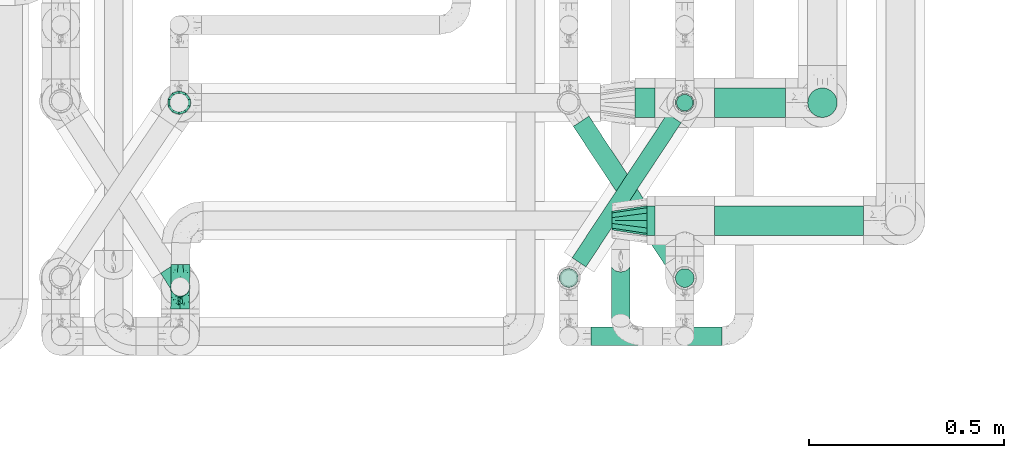
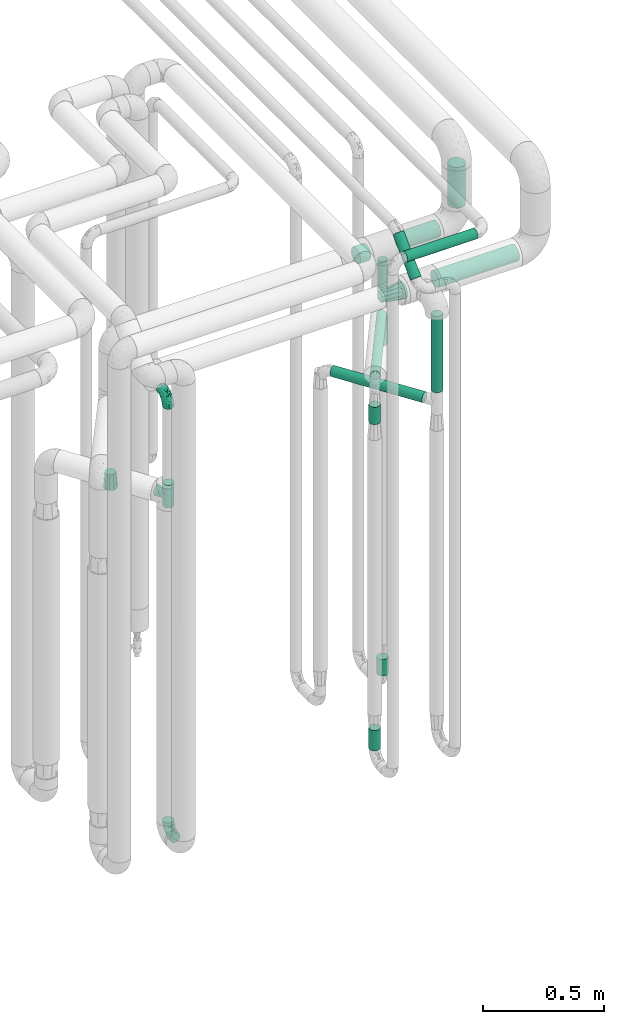
# One storey, part 663 of 827: 15 flow segments, 5 flow fittings.
"""IFC2X3 building model written with IfcOpenShell, lengths in millimetres."""

from ifc_helpers import new_model, entity, si_unit, converted_unit, derived_unit, direction, frame, origin, origin_2d_with_axis, place, context, subcontext, project, spatial, circle, extrude, faceted_brep, source, transform, mapped, material, type_object, type_shapes, element, save


model = new_model("IFC2X3")

# Units and contexts
model_context = context("Model", 3, precision=0.01, world=origin(), true_north=direction((6.12303176911189e-17, 1.0)))
body_context = subcontext(model_context, "Body", "Model", "MODEL_VIEW")
ifc_project = project(units=[si_unit("LENGTHUNIT", "METRE", prefix="MILLI"), si_unit("AREAUNIT", "SQUARE_METRE"), si_unit("VOLUMEUNIT", "CUBIC_METRE"), converted_unit("PLANEANGLEUNIT", "DEGREE", entity("IfcRatioMeasure", 0.0174532925199433), si_unit("PLANEANGLEUNIT", "RADIAN"), dimensions=[0, 0, 0, 0, 0, 0, 0]), si_unit("MASSUNIT", "GRAM", prefix="KILO"), derived_unit("MASSDENSITYUNIT", [(si_unit("MASSUNIT", "GRAM", prefix="KILO"), 1), (si_unit("LENGTHUNIT", "METRE"), -3)]), derived_unit("MOMENTOFINERTIAUNIT", [(si_unit("LENGTHUNIT", "METRE"), 4)]), si_unit("TIMEUNIT", "SECOND"), si_unit("FREQUENCYUNIT", "HERTZ"), si_unit("THERMODYNAMICTEMPERATUREUNIT", "DEGREE_CELSIUS"), derived_unit("THERMALTRANSMITTANCEUNIT", [(si_unit("MASSUNIT", "GRAM", prefix="KILO"), 1), (si_unit("THERMODYNAMICTEMPERATUREUNIT", "KELVIN"), -1), (si_unit("TIMEUNIT", "SECOND"), -3)]), derived_unit("VOLUMETRICFLOWRATEUNIT", [(si_unit("LENGTHUNIT", "METRE"), 3), (si_unit("TIMEUNIT", "SECOND"), -1)]), derived_unit("MASSFLOWRATEUNIT", [(si_unit("MASSUNIT", "GRAM", prefix="KILO"), 1), (si_unit("TIMEUNIT", "SECOND"), -1)]), derived_unit("ROTATIONALFREQUENCYUNIT", [(si_unit("TIMEUNIT", "SECOND"), -1)]), si_unit("ELECTRICCURRENTUNIT", "AMPERE"), si_unit("ELECTRICVOLTAGEUNIT", "VOLT"), si_unit("POWERUNIT", "WATT"), si_unit("FORCEUNIT", "NEWTON", prefix="KILO"), si_unit("ILLUMINANCEUNIT", "LUX"), si_unit("LUMINOUSFLUXUNIT", "LUMEN"), si_unit("LUMINOUSINTENSITYUNIT", "CANDELA"), derived_unit("USERDEFINED", [(si_unit("MASSUNIT", "GRAM", prefix="KILO"), -1), (si_unit("LENGTHUNIT", "METRE"), -2), (si_unit("TIMEUNIT", "SECOND"), 3), (si_unit("LUMINOUSFLUXUNIT", "LUMEN"), 1)]), derived_unit("LINEARVELOCITYUNIT", [(si_unit("LENGTHUNIT", "METRE"), 1), (si_unit("TIMEUNIT", "SECOND"), -1)]), si_unit("PRESSUREUNIT", "PASCAL"), derived_unit("USERDEFINED", [(si_unit("LENGTHUNIT", "METRE"), -2), (si_unit("MASSUNIT", "GRAM", prefix="KILO"), 1), (si_unit("TIMEUNIT", "SECOND"), -2)]), derived_unit("LINEARFORCEUNIT", [(si_unit("MASSUNIT", "GRAM", prefix="KILO"), 1), (si_unit("LENGTHUNIT", "METRE"), 1), (si_unit("TIMEUNIT", "SECOND"), -2), (si_unit("LENGTHUNIT", "METRE"), -1)]), derived_unit("PLANARFORCEUNIT", [(si_unit("MASSUNIT", "GRAM", prefix="KILO"), 1), (si_unit("LENGTHUNIT", "METRE"), 1), (si_unit("TIMEUNIT", "SECOND"), -2), (si_unit("LENGTHUNIT", "METRE"), -2)])], contexts=[model_context])

# Site, building, storey
site_placement = place(None, origin())
site = spatial("IfcSite", under=ifc_project, at=site_placement, CompositionType="ELEMENT")
building_placement = place(site_placement, origin())
building = spatial("IfcBuilding", under=site, at=building_placement, CompositionType="ELEMENT")
storey_placement = place(building_placement, frame((0.0, 0.0, 28200.0)))
storey = spatial("IfcBuildingStorey", under=building, at=storey_placement, Name="08", CompositionType="ELEMENT", Elevation=28200.0)

# Flow segments
pipe_segment_type = type_object("IfcPipeSegmentType", PredefinedType="NOTDEFINED")
flow_segment_1_placement = place(storey_placement, frame((48195.03, 13894.16, 2558.15)))
element("IfcFlowSegment", 1, at=flow_segment_1_placement, inside=storey, type_object=pipe_segment_type, context=body_context, shape_type="SweptSolid", body=[
    extrude(circle(Radius=37.75, at=origin_2d_with_axis()), frame((0.0, 39.35, 39.35), z_axis=(1.0, 0.0, 0.0), x_axis=(0.0, 1.0, 0.0)), (0.0, 0.0, 1.0), 20.9896740925879),
])
flow_segment_2_placement = place(storey_placement, frame((48605.5, 14196.33, 2700.0)))
element("IfcFlowSegment", 2, at=flow_segment_2_placement, inside=storey, type_object=pipe_segment_type, context=body_context, shape_type="SweptSolid", body=[
    extrude(circle(Radius=37.75, at=origin_2d_with_axis()), frame((39.35, 39.35, 0.0)), (0.0, 0.0, 1.0), 205.000000000018),
])
flow_segment_3_placement = place(storey_placement, frame((48368.02, 13894.16, 2558.15)))
element("IfcFlowSegment", 3, at=flow_segment_3_placement, inside=storey, type_object=pipe_segment_type, context=body_context, shape_type="SweptSolid", body=[
    extrude(circle(Radius=37.75, at=origin_2d_with_axis()), frame((0.0, 39.35, 39.35), z_axis=(1.0, 0.0, 0.0), x_axis=(0.0, 1.0, 0.0)), (0.0, 0.0, 1.0), 382.010325907433),
])
flow_segment_4_placement = place(storey_placement, frame((48164.84, 14196.33, 2565.65)))
element("IfcFlowSegment", 4, at=flow_segment_4_placement, inside=storey, type_object=pipe_segment_type, context=body_context, shape_type="SweptSolid", body=[
    extrude(circle(Radius=37.75, at=origin_2d_with_axis()), frame((0.0, 39.35, 39.35), z_axis=(1.0, 0.0, 0.0), x_axis=(0.0, 1.0, 0.0)), (0.0, 0.0, 1.0), 51.1810195864036),
])
flow_segment_5_placement = place(storey_placement, frame((48051.84, 13611.24, 2974.4)))
element("IfcFlowSegment", 5, at=flow_segment_5_placement, inside=storey, type_object=pipe_segment_type, context=body_context, shape_type="SweptSolid", body=[
    extrude(circle(Radius=24.0, at=origin_2d_with_axis()), frame((0.0, 25.6, 25.6), z_axis=(1.0, 0.0, 0.0), x_axis=(0.0, 1.0, 0.0)), (0.0, 0.0, 1.0), 336.00000000001),
])
flow_segment_6_placement = place(storey_placement, frame((48102.22, 13658.43, 2821.88)))
element("IfcFlowSegment", 6, at=flow_segment_6_placement, inside=storey, type_object=pipe_segment_type, context=body_context, shape_type="SweptSolid", body=[
    extrude(circle(Radius=24.0, at=origin_2d_with_axis()), frame((25.6, 18.61, 18.52), z_axis=(2.9457982268179e-07, 0.705313064929199, 0.708895958826183), x_axis=(1.0, -4.17658253234449e-07, 0.0)), (0.0, 0.0, 1.0), 201.434345622955),
])
flow_segment_7_placement = place(storey_placement, frame((48266.43, 14210.08, 457.0)))
element("IfcFlowSegment", 7, at=flow_segment_7_placement, inside=storey, type_object=pipe_segment_type, context=body_context, shape_type="SweptSolid", body=[
    extrude(circle(Radius=24.0, at=origin_2d_with_axis()), frame((25.6, 25.6, 0.0), z_axis=(0.0, 0.0, 1.0), x_axis=(-1.0, 0.0, 0.0)), (0.0, 0.0, 1.0), 84.021536088702),
])
flow_segment_8_placement = place(storey_placement, frame((48269.28, 14212.93, 2117.5)))
element("IfcFlowSegment", 8, at=flow_segment_8_placement, inside=storey, type_object=pipe_segment_type, context=body_context, shape_type="SweptSolid", body=[
    extrude(circle(Radius=21.15, at=origin_2d_with_axis()), frame((22.75, 22.75, 0.0)), (0.0, 0.0, 1.0), 134.500000000013),
])
flow_segment_9_placement = place(storey_placement, frame((48368.02, 14196.33, 2565.65)))
element("IfcFlowSegment", 9, at=flow_segment_9_placement, inside=storey, type_object=pipe_segment_type, context=body_context, shape_type="SweptSolid", body=[
    extrude(circle(Radius=37.75, at=origin_2d_with_axis()), frame((0.0, 39.35, 39.35), z_axis=(1.0, 0.0, 0.0), x_axis=(0.0, 1.0, 0.0)), (0.0, 0.0, 1.0), 181.818980413621),
])
flow_segment_10_placement = place(storey_placement, frame((48001.84, 13813.13, 2277.25)))
element("IfcFlowSegment", 10, at=flow_segment_10_placement, inside=storey, type_object=pipe_segment_type, context=body_context, shape_type="SweptSolid", body=[
    extrude(circle(Radius=21.15, at=origin_2d_with_axis()), frame((19.24, 13.25, 22.75), z_axis=(0.551214458685239, 0.834363602116211, 0.0), x_axis=(0.834363602116211, -0.551214458685239, 0.0)), (0.0, 0.0, 1.0), 442.846744306642),
])
flow_segment_11_placement = place(storey_placement, frame((48269.28, 14212.93, 2348.0)))
element("IfcFlowSegment", 11, at=flow_segment_11_placement, inside=storey, type_object=pipe_segment_type, context=body_context, shape_type="SweptSolid", body=[
    extrude(circle(Radius=21.15, at=origin_2d_with_axis()), frame((22.75, 22.75, 0.0)), (0.0, 0.0, 1.0), 192.999999999991),
])
flow_segment_12_placement = place(storey_placement, frame((47969.25, 13760.6, 457.0)))
element("IfcFlowSegment", 12, at=flow_segment_12_placement, inside=storey, type_object=pipe_segment_type, context=body_context, shape_type="SweptSolid", body=[
    extrude(circle(Radius=24.0, at=origin_2d_with_axis()), frame((25.6, 25.6, 0.0), z_axis=(0.0, 0.0, 1.0), x_axis=(-1.0, 0.0, 0.0)), (0.0, 0.0, 1.0), 103.000000000011),
])
flow_segment_13_placement = place(storey_placement, frame((47969.25, 13760.6, 2100.0)))
element("IfcFlowSegment", 13, at=flow_segment_13_placement, inside=storey, type_object=pipe_segment_type, context=body_context, shape_type="SweptSolid", body=[
    extrude(circle(Radius=24.0, at=origin_2d_with_axis()), frame((25.6, 25.6, 0.0)), (0.0, 0.0, 1.0), 88.000000000006),
])
flow_segment_14_placement = place(storey_placement, frame((48266.43, 13760.5, 2157.0)))
element("IfcFlowSegment", 14, at=flow_segment_14_placement, inside=storey, type_object=pipe_segment_type, context=body_context, shape_type="SweptSolid", body=[
    extrude(circle(Radius=24.0, at=origin_2d_with_axis()), frame((25.6, 25.6, 0.0)), (0.0, 0.0, 1.0), 383.500002566644),
])
flow_segment_15_placement = place(storey_placement, frame((48004.66, 13818.82, 2074.4)))
element("IfcFlowSegment", 15, at=flow_segment_15_placement, inside=storey, type_object=pipe_segment_type, context=body_context, shape_type="SweptSolid", body=[
    extrude(circle(Radius=24.0, at=origin_2d_with_axis()), frame((255.94, 14.83, 25.6), z_axis=(-0.55144120068557, 0.834213762884824, 0.0), x_axis=(0.834213762884824, 0.55144120068557, 0.0)), (0.0, 0.0, 1.0), 424.922551345866),
])

# Flow fittings
ifc_material = material()
pipe_fitting_type_1 = type_object("IfcPipeFittingType", Name="ADSK_1", PredefinedType="NOTDEFINED", material=ifc_material)
shared_shape_1 = source(origin(), body_context, "Body", "Brep", [
    faceted_brep([(-57.0, 12.07, -20.91), (-57.0, 6.25, -23.33), (-57.0, 0.0, -24.15), (-57.0, -6.25, -23.33), (-57.0, -12.08, -20.91), (-57.0, -17.08, -17.08), (-57.0, -20.91, -12.08), (-57.0, -23.33, -6.25), (-57.0, -24.15, 0.0), (-57.0, -23.33, 6.25), (-57.0, -20.91, 12.07), (-57.0, -17.08, 17.08), (-57.0, -12.08, 20.91), (-57.0, -6.25, 23.33), (-57.0, 0.0, 24.15), (-57.0, 6.25, 23.33), (-57.0, 12.07, 20.91), (-57.0, 17.08, 17.08), (-57.0, 20.91, 12.07), (-57.0, 23.33, 6.25), (-57.0, 24.15, 0.0), (-57.0, 23.33, -6.25), (-57.0, 20.91, -12.08), (-57.0, 17.08, -17.08), (0.0, 57.0, -24.15), (-6.25, 57.0, -23.33), (-12.07, 57.0, -20.91), (-17.08, 57.0, -17.08), (-20.91, 57.0, -12.08), (-23.33, 57.0, -6.25), (-24.15, 57.0, 0.0), (-23.33, 57.0, 6.25), (-20.91, 57.0, 12.07), (-17.08, 57.0, 17.08), (-12.07, 57.0, 20.91), (-6.25, 57.0, 23.33), (0.0, 57.0, 24.15), (6.25, 57.0, 23.33), (12.08, 57.0, 20.91), (17.08, 57.0, 17.08), (20.91, 57.0, 12.07), (23.33, 57.0, 6.25), (24.15, 57.0, 0.0), (23.33, 57.0, -6.25), (20.91, 57.0, -12.08), (17.08, 57.0, -17.08), (12.08, 57.0, -20.91), (6.25, 57.0, -23.33), (14.9, 21.14, 6.17), (13.61, 24.64, 12.48), (6.23, 8.95, 8.98), (-41.47, -21.06, 0.0), (-41.92, -18.38, 13.72), (-24.64, -13.61, 12.48), (-37.37, -13.24, 18.15), (-6.8, -4.93, 8.18), (-21.76, -15.19, 6.22), (-12.78, -9.18, 0.0), (-37.73, -20.51, 7.75), (-7.38, 7.38, 20.24), (-23.37, -4.26, 20.42), (-11.9, -3.19, 15.86), (-42.14, -8.7, 21.82), (13.24, 37.37, 18.15), (9.33, 23.53, 16.85), (4.26, 23.37, 20.42), (2.77, 10.92, 15.55), (-29.46, 0.91, 23.52), (-44.13, 20.56, 15.69), (-39.25, 26.33, 10.88), (-49.02, 22.92, 9.96), (-34.58, 23.87, 17.15), (-15.8, 6.8, 22.81), (-8.67, 20.47, 23.88), (-18.12, 12.9, 24.08), (-48.29, 14.92, 19.65), (-44.06, -2.85, 23.78), (-9.23, 48.95, 22.58), (-3.78, 42.74, 24.07), (-40.34, 4.26, 24.09), (-44.02, 26.14, 5.46), (-44.04, 9.88, 22.74), (-4.95, 16.87, 22.52), (-2.75, 1.43, 12.5), (-25.48, 40.98, 10.71), (20.51, 37.73, 7.75), (18.38, 41.92, 13.72), (8.7, 42.14, 21.82), (-25.95, -17.97, 0.0), (2.85, 44.06, 23.78), (21.06, 41.47, 0.0), (17.97, 25.95, 0.0), (-24.04, -9.27, 17.13), (-33.26, 33.26, 5.86), (-28.55, 40.57, 0.0), (-40.57, 28.55, 0.0), (-25.29, 47.19, 4.06), (-27.01, 31.1, 16.77), (-15.7, 43.95, 19.9), (-20.27, 45.22, 15.61), (-30.53, 31.98, 12.64), (-11.28, 38.33, 22.92), (-9.97, 27.88, 24.09), (-20.15, 30.26, 21.25), (-31.25, 11.75, 23.64), (-28.75, 7.23, 24.15), (-29.53, 18.06, 22.27), (-28.44, 24.21, 20.02), (-37.55, 17.7, 20.26), (-15.88, 29.25, 22.99), (-20.82, 20.82, 23.44), (-0.91, 29.46, 23.52), (-13.5, -7.67, 12.04), (1.49, 1.56, 5.16), (8.86, 10.35, 4.59), (0.38, -0.38, 0.0), (9.18, 12.78, 0.0), (-37.37, -13.24, -18.15), (8.86, 10.35, -4.59), (-45.22, 20.27, -15.61), (-43.95, 15.7, -19.9), (-38.33, 11.28, -22.92), (-48.95, 9.23, -22.58), (-47.19, 25.29, -4.06), (-33.26, 33.26, -5.86), (18.38, 41.92, -13.72), (-30.26, 20.15, -21.25), (2.85, 44.06, -23.78), (-4.26, 40.34, -24.09), (-40.98, 25.48, -10.71), (-41.92, -18.38, -13.72), (9.25, 23.5, -16.92), (4.26, 23.37, -20.42), (13.24, 37.37, -18.15), (-37.73, -20.51, -7.75), (-11.75, 31.25, -23.64), (-7.23, 28.75, -24.15), (-12.9, 18.12, -24.08), (8.7, 42.14, -21.82), (-44.06, -2.85, -23.78), (-6.8, 15.8, -22.81), (-20.47, 8.67, -23.88), (-24.64, -13.61, -12.48), (-42.74, 3.78, -24.07), (-18.06, 29.53, -22.27), (-24.21, 28.44, -20.02), (-27.88, 9.97, -24.09), (-31.1, 27.01, -16.77), (-26.14, 44.02, -5.46), (14.9, 21.14, -6.17), (20.51, 37.73, -7.75), (-9.88, 44.04, -22.74), (-20.56, 44.13, -15.69), (-21.76, -15.19, -6.22), (-13.5, -7.67, -12.04), (-24.14, -9.76, -16.74), (-11.9, -3.19, -15.86), (-14.92, 48.29, -19.65), (-23.37, -4.26, -20.42), (-0.91, 29.46, -23.52), (-26.33, 39.25, -10.88), (-23.87, 34.58, -17.15), (-42.14, -8.7, -21.82), (-22.92, 49.02, -9.96), (13.61, 24.64, -12.48), (-31.98, 30.53, -12.64), (-16.87, 4.95, -22.52), (-17.7, 37.55, -20.26), (-29.25, 15.88, -22.99), (-20.82, 20.82, -23.44), (-29.46, 0.91, -23.52), (-7.38, 7.38, -20.24), (2.77, 10.92, -15.55), (6.23, 8.95, -8.98), (-6.8, -4.93, -8.18), (-2.81, 1.41, -12.54), (1.49, 1.56, -5.16)], [[[0, 1, 2, 3, 4, 5, 6, 7, 8, 9, 10, 11, 12, 13, 14, 15, 16, 17, 18, 19, 20, 21, 22, 23]], [[24, 25, 26, 27, 28, 29, 30, 31, 32, 33, 34, 35, 36, 37, 38, 39, 40, 41, 42, 43, 44, 45, 46, 47]], [[48, 49, 50]], [[9, 8, 51]], [[52, 53, 54]], [[55, 56, 57]], [[10, 58, 52]], [[9, 58, 10]], [[59, 60, 61]], [[54, 12, 11]], [[54, 62, 12]], [[63, 39, 38]], [[64, 65, 66]], [[62, 60, 67]], [[68, 69, 70]], [[71, 69, 68]], [[72, 73, 74]], [[16, 75, 17]], [[13, 76, 14]], [[35, 77, 78]], [[14, 79, 15]], [[17, 68, 18]], [[14, 76, 79]], [[20, 19, 80]], [[70, 19, 18]], [[81, 15, 79]], [[15, 81, 16]], [[73, 72, 82]], [[66, 83, 50]], [[32, 31, 84]], [[85, 86, 49]], [[63, 87, 65]], [[56, 58, 88]], [[36, 89, 37]], [[85, 41, 40]], [[36, 35, 78]], [[90, 41, 85]], [[40, 39, 86]], [[12, 62, 13]], [[86, 85, 40]], [[48, 85, 49]], [[85, 91, 90]], [[87, 38, 37]], [[92, 60, 54]], [[80, 69, 93]], [[93, 94, 95]], [[10, 52, 11]], [[94, 96, 30]], [[97, 98, 99]], [[80, 93, 95]], [[100, 97, 84]], [[99, 98, 33]], [[101, 102, 78]], [[103, 101, 98]], [[96, 31, 30]], [[77, 98, 101]], [[77, 35, 34]], [[34, 33, 98]], [[9, 51, 58]], [[87, 63, 38]], [[104, 105, 74]], [[106, 103, 107]], [[106, 81, 104]], [[75, 68, 17]], [[108, 107, 71]], [[33, 32, 99]], [[109, 103, 110]], [[101, 109, 102]], [[89, 78, 111]], [[53, 52, 58]], [[54, 11, 52]], [[60, 62, 54]], [[88, 58, 51]], [[76, 62, 67]], [[53, 112, 92]], [[60, 59, 72]], [[39, 63, 86]], [[49, 86, 63]], [[89, 87, 37]], [[42, 41, 90]], [[111, 82, 65]], [[111, 65, 87]], [[65, 59, 66]], [[104, 81, 79]], [[75, 81, 108]], [[32, 84, 99]], [[97, 99, 84]], [[98, 97, 103]], [[106, 107, 108]], [[74, 102, 110]], [[111, 78, 102]], [[74, 110, 104]], [[74, 67, 72]], [[61, 92, 112]], [[66, 59, 61]], [[56, 53, 58]], [[66, 50, 49]], [[61, 112, 83]], [[66, 49, 64]], [[78, 89, 36]], [[87, 89, 111]], [[62, 76, 13]], [[79, 76, 67]], [[100, 93, 69]], [[96, 93, 84]], [[55, 113, 50]], [[113, 114, 50]], [[104, 79, 105]], [[106, 104, 110]], [[20, 80, 95]], [[85, 48, 91]], [[115, 114, 113]], [[116, 91, 48]], [[70, 80, 19]], [[93, 96, 94]], [[84, 31, 96]], [[103, 106, 110]], [[81, 106, 108]], [[103, 97, 107]], [[71, 107, 97]], [[71, 97, 100]], [[108, 71, 68]], [[79, 67, 105]], [[67, 74, 105]], [[115, 113, 57]], [[112, 56, 55]], [[56, 88, 57]], [[60, 72, 67]], [[82, 72, 59]], [[65, 82, 59]], [[82, 111, 73]], [[111, 102, 73]], [[102, 74, 73]], [[81, 75, 16]], [[68, 75, 108]], [[68, 70, 18]], [[80, 70, 69]], [[98, 77, 34]], [[78, 77, 101]], [[93, 100, 84]], [[71, 100, 69]], [[102, 109, 110]], [[101, 103, 109]], [[53, 92, 54]], [[61, 60, 92]], [[56, 112, 53]], [[83, 112, 55]], [[50, 83, 55]], [[61, 83, 66]], [[49, 63, 64]], [[65, 64, 63]], [[57, 113, 55]], [[114, 115, 116]], [[116, 48, 114]], [[48, 50, 114]], [[117, 5, 4]], [[116, 115, 118]], [[119, 120, 23]], [[121, 122, 120]], [[95, 123, 20]], [[0, 23, 120]], [[124, 95, 94]], [[125, 45, 44]], [[121, 120, 126]], [[24, 127, 128]], [[22, 21, 129]], [[0, 122, 1]], [[5, 117, 130]], [[131, 132, 133]], [[134, 88, 51]], [[135, 136, 137]], [[6, 5, 130]], [[46, 138, 47]], [[139, 3, 2]], [[140, 141, 137]], [[6, 134, 7]], [[134, 130, 142]], [[143, 2, 1]], [[144, 126, 145]], [[121, 146, 143]], [[147, 120, 119]], [[94, 148, 124]], [[149, 150, 91]], [[30, 29, 148]], [[151, 25, 128]], [[27, 152, 28]], [[134, 153, 88]], [[154, 155, 156]], [[27, 26, 157]], [[151, 26, 25]], [[155, 158, 156]], [[24, 47, 127]], [[1, 122, 143]], [[138, 132, 159]], [[160, 152, 161]], [[24, 128, 25]], [[46, 133, 138]], [[162, 117, 4]], [[148, 160, 124]], [[152, 160, 163]], [[154, 142, 155]], [[45, 125, 133]], [[133, 46, 45]], [[125, 164, 133]], [[51, 7, 134]], [[42, 90, 43]], [[165, 147, 129]], [[153, 134, 142]], [[43, 150, 44]], [[162, 4, 3]], [[141, 140, 166]], [[117, 162, 158]], [[163, 29, 28]], [[43, 90, 150]], [[123, 21, 20]], [[144, 151, 135]], [[157, 152, 27]], [[167, 145, 161]], [[23, 22, 119]], [[168, 126, 169]], [[121, 168, 146]], [[139, 143, 170]], [[142, 130, 117]], [[8, 7, 51]], [[134, 6, 130]], [[139, 162, 3]], [[170, 166, 158]], [[170, 158, 162]], [[158, 171, 156]], [[44, 150, 125]], [[91, 150, 90]], [[164, 125, 150]], [[132, 138, 133]], [[127, 138, 159]], [[131, 164, 172]], [[132, 171, 140]], [[135, 151, 128]], [[157, 151, 167]], [[22, 129, 119]], [[147, 119, 129]], [[120, 147, 126]], [[144, 145, 167]], [[137, 146, 169]], [[170, 143, 146]], [[137, 169, 135]], [[137, 159, 140]], [[171, 172, 156]], [[173, 174, 175]], [[156, 175, 154]], [[174, 57, 153]], [[132, 172, 171]], [[172, 164, 173]], [[143, 139, 2]], [[162, 139, 170]], [[138, 127, 47]], [[128, 127, 159]], [[165, 124, 160]], [[123, 124, 129]], [[149, 173, 164]], [[176, 174, 173]], [[135, 128, 136]], [[144, 135, 169]], [[150, 149, 164]], [[176, 118, 115]], [[149, 91, 116]], [[30, 148, 94]], [[163, 148, 29]], [[124, 123, 95]], [[129, 21, 123]], [[126, 144, 169]], [[151, 144, 167]], [[126, 147, 145]], [[161, 145, 147]], [[161, 147, 165]], [[167, 161, 152]], [[128, 159, 136]], [[159, 137, 136]], [[154, 153, 142]], [[132, 140, 159]], [[174, 176, 57]], [[57, 88, 153]], [[166, 140, 171]], [[158, 166, 171]], [[166, 170, 141]], [[170, 146, 141]], [[146, 137, 141]], [[151, 157, 26]], [[152, 157, 167]], [[152, 163, 28]], [[148, 163, 160]], [[120, 122, 0]], [[143, 122, 121]], [[124, 165, 129]], [[161, 165, 160]], [[146, 168, 169]], [[121, 126, 168]], [[142, 117, 155]], [[158, 155, 117]], [[175, 156, 172]], [[153, 154, 174]], [[173, 175, 172]], [[174, 154, 175]], [[164, 131, 133]], [[172, 132, 131]], [[176, 173, 118]], [[57, 176, 115]], [[173, 149, 118]], [[149, 116, 118]]]),
])
type_shapes(pipe_fitting_type_1, [shared_shape_1])
for number, where, z_axis, x_axis, name in (
    (16, (46998.53, 13763.77, 400.0), (1.0, 0.0, 0.0), (0.0, 1.0, 0.0), "ADSK_1"),
    (17, (46998.53, 13763.77, 2597.45), (-0.999819445610939, 0.0190020045846528, 0.0), (0.0, 0.0, 1.0), "ADSK_1"),
):
    element("IfcFlowFitting", number, at=place(storey_placement, frame(where, z_axis=z_axis, x_axis=x_axis)), inside=storey, type_object=pipe_fitting_type_1, material=ifc_material, Name=name, ObjectType="ADSK_1", context=body_context, shape_type="MappedRepresentation", body=[
        mapped(shared_shape_1, transform((0.0, 0.0, 0.0), scale=1.0)),
    ])
pipe_fitting_type_2 = type_object("IfcPipeFittingType", Name="ADSK_1", PredefinedType="NOTDEFINED", material=ifc_material)
shared_shape_2 = source(origin(), body_context, "Body", "Brep", [
    faceted_brep([(-57.0, 12.07, -20.91), (-57.0, 6.25, -23.33), (-57.0, 0.0, -24.15), (-57.0, -6.25, -23.33), (-57.0, -12.08, -20.91), (-57.0, -17.08, -17.08), (-57.0, -20.91, -12.08), (-57.0, -23.33, -6.25), (-57.0, -24.15, 0.0), (-57.0, -23.33, 6.25), (-57.0, -20.91, 12.07), (-57.0, -17.08, 17.08), (-57.0, -12.08, 20.91), (-57.0, -6.25, 23.33), (-57.0, 0.0, 24.15), (-57.0, 6.25, 23.33), (-57.0, 12.07, 20.91), (-57.0, 17.08, 17.08), (-57.0, 20.91, 12.07), (-57.0, 23.33, 6.25), (-57.0, 24.15, 0.0), (-57.0, 23.33, -6.25), (-57.0, 20.91, -12.08), (-57.0, 17.08, -17.08), (57.0, 0.0, -24.15), (57.0, 6.25, -23.33), (57.0, 12.07, -20.91), (57.0, 17.08, -17.08), (57.0, 20.91, -12.08), (57.0, 23.33, -6.25), (57.0, 24.15, 0.0), (57.0, 23.33, 6.25), (57.0, 20.91, 12.07), (57.0, 17.08, 17.08), (57.0, 12.07, 20.91), (57.0, 6.25, 23.33), (57.0, 0.0, 24.15), (57.0, -6.25, 23.33), (57.0, -12.08, 20.91), (57.0, -17.08, 17.08), (57.0, -20.91, 12.07), (57.0, -23.33, 6.25), (57.0, -24.15, 0.0), (57.0, -23.33, -6.25), (57.0, -20.91, -12.08), (57.0, -17.08, -17.08), (57.0, -12.08, -20.91), (57.0, -6.25, -23.33), (23.27, -23.27, 6.45), (24.15, -24.15, 0.0), (-24.15, -24.15, 0.0), (20.9, -20.9, 12.1), (13.54, -13.54, 20.0), (17.52, -17.52, 16.62), (-23.27, -23.27, 6.45), (-20.9, -20.9, 12.1), (-17.52, -17.52, 16.62), (-13.54, -13.54, 20.0), (-9.19, -9.19, 22.33), (9.19, -9.19, 22.33), (4.64, -4.64, 23.7), (0.0, 0.0, 24.15), (-4.64, -4.64, 23.7), (4.64, -4.64, -23.7), (0.0, 0.0, -24.15), (-4.64, -4.64, -23.7), (-9.19, -9.19, -22.33), (9.19, -9.19, -22.33), (13.54, -13.54, -20.0), (17.52, -17.52, -16.62), (20.9, -20.9, -12.1), (23.27, -23.27, -6.45), (-13.54, -13.54, -20.0), (-17.52, -17.52, -16.62), (-23.27, -23.27, -6.45), (-20.9, -20.9, -12.1), (0.0, -57.0, -24.15), (6.25, -57.0, -23.33), (12.08, -57.0, -20.91), (17.08, -57.0, -17.08), (20.91, -57.0, -12.08), (23.33, -57.0, -6.25), (24.15, -57.0, 0.0), (23.33, -57.0, 6.25), (20.91, -57.0, 12.07), (17.08, -57.0, 17.08), (12.08, -57.0, 20.91), (6.25, -57.0, 23.33), (0.0, -57.0, 24.15), (-6.25, -57.0, 23.33), (-12.07, -57.0, 20.91), (-17.08, -57.0, 17.08), (-20.91, -57.0, 12.07), (-23.33, -57.0, 6.25), (-24.15, -57.0, 0.0), (-23.33, -57.0, -6.25), (-20.91, -57.0, -12.08), (-17.08, -57.0, -17.08), (-12.07, -57.0, -20.91), (-6.25, -57.0, -23.33)], [[[0, 1, 2, 3, 4, 5, 6, 7, 8, 9, 10, 11, 12, 13, 14, 15, 16, 17, 18, 19, 20, 21, 22, 23]], [[24, 25, 26, 27, 28, 29, 30, 31, 32, 33, 34, 35, 36, 37, 38, 39, 40, 41, 42, 43, 44, 45, 46, 47]], [[41, 40, 48]], [[42, 41, 49]], [[50, 9, 8]], [[49, 41, 48]], [[40, 51, 48]], [[39, 38, 52]], [[51, 40, 53]], [[52, 53, 39]], [[53, 40, 39]], [[50, 54, 9]], [[9, 54, 10]], [[54, 55, 10]], [[56, 57, 11]], [[11, 10, 56]], [[11, 57, 12]], [[56, 10, 55]], [[12, 57, 58]], [[52, 38, 59]], [[60, 36, 61]], [[62, 61, 14]], [[59, 37, 60]], [[37, 59, 38]], [[60, 37, 36]], [[61, 36, 35, 15, 14]], [[32, 31, 19, 18]], [[17, 16, 34, 33]], [[18, 17, 33, 32]], [[35, 34, 16, 15]], [[20, 19, 31, 30]], [[62, 13, 58]], [[13, 62, 14]], [[58, 13, 12]], [[27, 23, 22, 28]], [[22, 21, 29, 28]], [[0, 23, 27, 26]], [[20, 30, 29, 21]], [[24, 47, 63]], [[24, 64, 2, 1, 25]], [[64, 24, 63]], [[2, 64, 65]], [[26, 25, 1, 0]], [[65, 66, 3]], [[2, 65, 3]], [[66, 4, 3]], [[63, 47, 67]], [[46, 45, 68]], [[69, 68, 45]], [[44, 70, 69]], [[69, 45, 44]], [[46, 68, 67]], [[43, 42, 49]], [[7, 50, 8]], [[43, 71, 44]], [[71, 43, 49]], [[44, 71, 70]], [[72, 4, 66]], [[72, 5, 4]], [[5, 72, 73]], [[5, 73, 6]], [[74, 50, 7]], [[75, 74, 6]], [[74, 7, 6]], [[75, 6, 73]], [[46, 67, 47]], [[76, 77, 78, 79, 80, 81, 82, 83, 84, 85, 86, 87, 88, 89, 90, 91, 92, 93, 94, 95, 96, 97, 98, 99]], [[50, 94, 93]], [[54, 50, 93]], [[91, 90, 57]], [[56, 92, 91]], [[54, 93, 92]], [[58, 90, 89]], [[55, 54, 92]], [[56, 55, 92]], [[58, 57, 90]], [[88, 61, 62]], [[58, 89, 62]], [[56, 91, 57]], [[62, 89, 88]], [[60, 88, 87]], [[86, 59, 87]], [[84, 83, 48]], [[53, 85, 84]], [[52, 86, 85]], [[49, 83, 82]], [[59, 60, 87]], [[52, 59, 86]], [[49, 48, 83]], [[51, 53, 84]], [[48, 51, 84]], [[52, 85, 53]], [[88, 60, 61]], [[82, 81, 49]], [[71, 49, 81]], [[69, 80, 79]], [[79, 78, 68]], [[71, 81, 80]], [[67, 78, 77]], [[70, 71, 80]], [[69, 70, 80]], [[67, 68, 78]], [[76, 64, 63]], [[67, 77, 63]], [[69, 79, 68]], [[63, 77, 76]], [[65, 76, 99]], [[98, 66, 99]], [[96, 95, 74]], [[73, 97, 96]], [[72, 98, 97]], [[50, 95, 94]], [[66, 65, 99]], [[72, 66, 98]], [[50, 74, 95]], [[75, 73, 96]], [[74, 75, 96]], [[72, 97, 73]], [[76, 65, 64]]]),
])
type_shapes(pipe_fitting_type_2, [shared_shape_2])
flow_fitting_1_placement = place(storey_placement, frame((46999.59, 13763.75, 2100.11), z_axis=(0.839206573460922, 0.543812768386306, 0.0), x_axis=(0.0, 0.0, 1.0)))
element("IfcFlowFitting", 18, at=flow_fitting_1_placement, inside=storey, type_object=pipe_fitting_type_2, material=ifc_material, Name="ADSK_1", ObjectType="ADSK_1", context=body_context, shape_type="MappedRepresentation", body=[
    mapped(shared_shape_2, transform((0.0, 0.0, 0.0), scale=1.0)),
])
pipe_fitting_type_3 = type_object("IfcPipeFittingType", Name="ADSK_1", PredefinedType="NOTDEFINED", material=ifc_material)
shared_shape_3 = source(origin(), body_context, "Body", "Brep", [
    faceted_brep([(89.0, 24.15, 0.0), (89.0, 21.84, 7.1), (89.0, 19.54, 14.2), (89.0, 13.5, 18.58), (89.0, 7.46, 22.97), (89.0, 0.0, 22.97), (89.0, -7.46, 22.97), (89.0, -13.5, 18.58), (89.0, -19.54, 14.2), (89.0, -21.84, 7.1), (89.0, -24.15, 0.0), (89.0, -21.84, -7.1), (89.0, -19.54, -14.2), (89.0, -13.5, -18.58), (89.0, -7.46, -22.97), (89.0, 0.0, -22.97), (89.0, 7.46, -22.97), (89.0, 13.5, -18.58), (89.0, 19.54, -14.2), (89.0, 21.84, -7.1), (0.0, 25.99, 25.99), (0.0, 32.95, 19.02), (0.0, 36.21, 6.85), (0.0, 38.05, 0.0), (0.0, 36.21, -6.85), (0.0, 32.95, -19.03), (0.0, 25.99, -25.99), (0.0, 19.03, -32.95), (0.0, 9.51, -35.5), (0.0, 0.0, -38.05), (0.0, -9.51, -35.5), (0.0, -19.03, -32.95), (0.0, -25.99, -25.99), (0.0, -32.95, -19.02), (0.0, -36.21, -6.85), (0.0, -38.05, 0.0), (0.0, -36.21, 6.85), (0.0, -32.95, 19.02), (0.0, -25.99, 25.99), (0.0, -19.02, 32.95), (0.0, -9.51, 35.5), (0.0, 0.0, 38.05), (0.0, 9.51, 35.5), (0.0, 19.02, 32.95)], [[[0, 1, 2, 3, 4, 5, 6, 7, 8, 9, 10, 11, 12, 13, 14, 15, 16, 17, 18, 19]], [[20, 21, 22, 23, 24, 25, 26, 27, 28, 29, 30, 31, 32, 33, 34, 35, 36, 37, 38, 39, 40, 41, 42, 43]], [[26, 17, 27]], [[25, 18, 26]], [[17, 26, 18]], [[25, 19, 18]], [[24, 0, 19]], [[31, 14, 13]], [[17, 16, 27]], [[28, 27, 16]], [[14, 30, 15]], [[16, 15, 28]], [[12, 32, 13]], [[10, 35, 34]], [[30, 29, 15]], [[10, 34, 11]], [[25, 24, 19]], [[14, 31, 30]], [[0, 24, 23]], [[11, 33, 12]], [[12, 33, 32]], [[33, 11, 34]], [[31, 13, 32]], [[28, 15, 29]], [[38, 7, 39]], [[37, 8, 38]], [[7, 38, 8]], [[37, 9, 8]], [[36, 10, 9]], [[43, 4, 3]], [[7, 6, 39]], [[40, 39, 6]], [[4, 42, 5]], [[6, 5, 40]], [[2, 20, 3]], [[0, 23, 22]], [[42, 41, 5]], [[0, 22, 1]], [[37, 36, 9]], [[4, 43, 42]], [[10, 36, 35]], [[1, 21, 2]], [[2, 21, 20]], [[21, 1, 22]], [[43, 3, 20]], [[40, 5, 41]]]),
])
type_shapes(pipe_fitting_type_3, [shared_shape_3])
flow_fitting_2_placement = place(storey_placement, frame((48195.03, 13933.51, 2597.5), z_axis=(0.0, 0.0, 1.0), x_axis=(-1.0, 0.0, 0.0)))
element("IfcFlowFitting", 19, at=flow_fitting_2_placement, inside=storey, type_object=pipe_fitting_type_3, material=ifc_material, Name="ADSK_1", ObjectType="ADSK_1", context=body_context, shape_type="MappedRepresentation", body=[
    mapped(shared_shape_3, transform((0.0, 0.0, 0.0), scale=1.0)),
])
pipe_fitting_type_4 = type_object("IfcPipeFittingType", Name="ADSK_1", PredefinedType="NOTDEFINED", material=ifc_material)
shared_shape_4 = source(origin(), body_context, "Body", "Brep", [
    faceted_brep([(76.0, 24.15, 0.0), (76.0, 21.84, 7.1), (76.0, 19.54, 14.2), (76.0, 13.5, 18.58), (76.0, 7.46, 22.97), (76.0, 0.0, 22.97), (76.0, -7.46, 22.97), (76.0, -13.5, 18.58), (76.0, -19.54, 14.2), (76.0, -21.84, 7.1), (76.0, -24.15, 0.0), (76.0, -21.84, -7.1), (76.0, -19.54, -14.2), (76.0, -13.5, -18.58), (76.0, -7.46, -22.97), (76.0, 0.0, -22.97), (76.0, 7.46, -22.97), (76.0, 13.5, -18.58), (76.0, 19.54, -14.2), (76.0, 21.84, -7.1), (0.0, -30.15, 0.0), (0.0, -27.27, 8.86), (0.0, -24.39, 17.72), (0.0, -16.85, 23.2), (0.0, -9.32, 28.67), (0.0, 0.0, 28.67), (0.0, 9.32, 28.67), (0.0, 16.85, 23.2), (0.0, 24.39, 17.72), (0.0, 26.33, 11.75), (0.0, 28.24, 5.87), (0.0, 30.15, 0.0), (0.0, 27.27, -8.86), (0.0, 24.39, -17.72), (0.0, 16.85, -23.2), (0.0, 9.32, -28.67), (0.0, 0.0, -28.67), (0.0, -9.32, -28.67), (0.0, -16.85, -23.2), (0.0, -24.39, -17.72), (0.0, -26.33, -11.75), (0.0, -28.24, -5.87)], [[[0, 1, 2, 3, 4, 5, 6, 7, 8, 9, 10, 11, 12, 13, 14, 15, 16, 17, 18, 19]], [[20, 21, 22, 23, 24, 25, 26, 27, 28, 29, 30, 31, 32, 33, 34, 35, 36, 37, 38, 39, 40, 41]], [[19, 18, 33, 32, 31, 0]], [[36, 35, 16, 15, 14, 37]], [[35, 34, 33, 18, 17, 16]], [[41, 40, 39, 12, 11, 10, 20]], [[14, 13, 12, 39, 38, 37]], [[9, 8, 22, 21, 20, 10]], [[25, 24, 6, 5, 4, 26]], [[24, 23, 22, 8, 7, 6]], [[30, 29, 28, 2, 1, 0, 31]], [[4, 3, 2, 28, 27, 26]]]),
])
type_shapes(pipe_fitting_type_4, [shared_shape_4])
flow_fitting_3_placement = place(storey_placement, frame((46996.03, 14235.68, 1849.0), z_axis=(-1.0, 0.0, 0.0), x_axis=(0.0, 0.0, 1.0)))
element("IfcFlowFitting", 20, at=flow_fitting_3_placement, inside=storey, type_object=pipe_fitting_type_4, material=ifc_material, Name="ADSK_1", ObjectType="ADSK_1", context=body_context, shape_type="MappedRepresentation", body=[
    mapped(shared_shape_4, transform((0.0, 0.0, 0.0), scale=1.0)),
])

save(model, "model.ifc")
